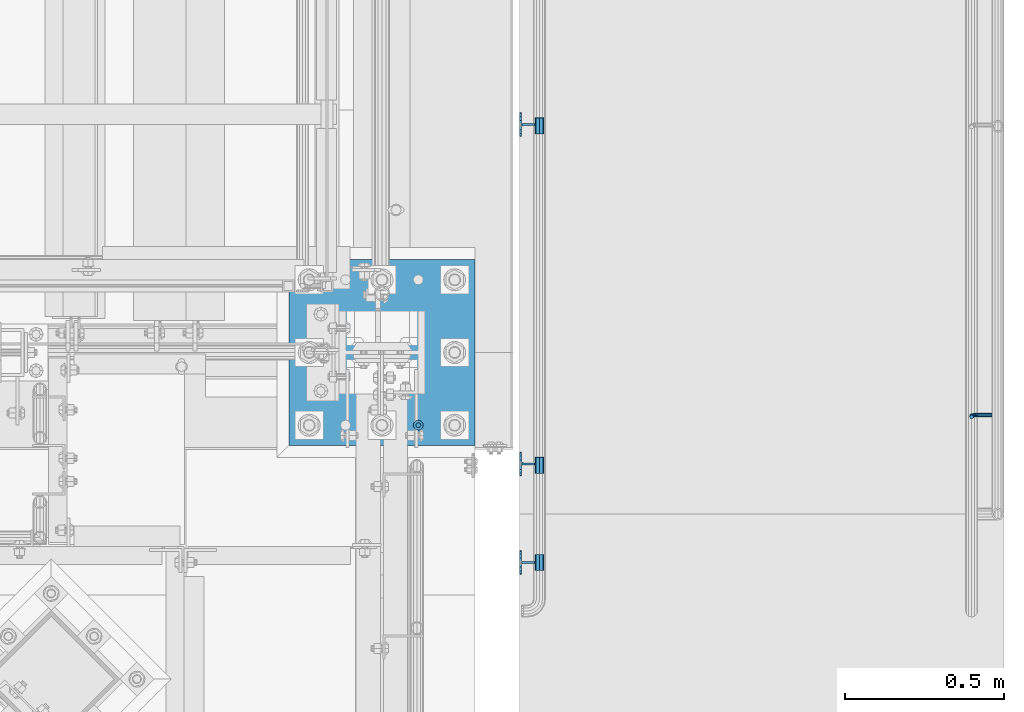
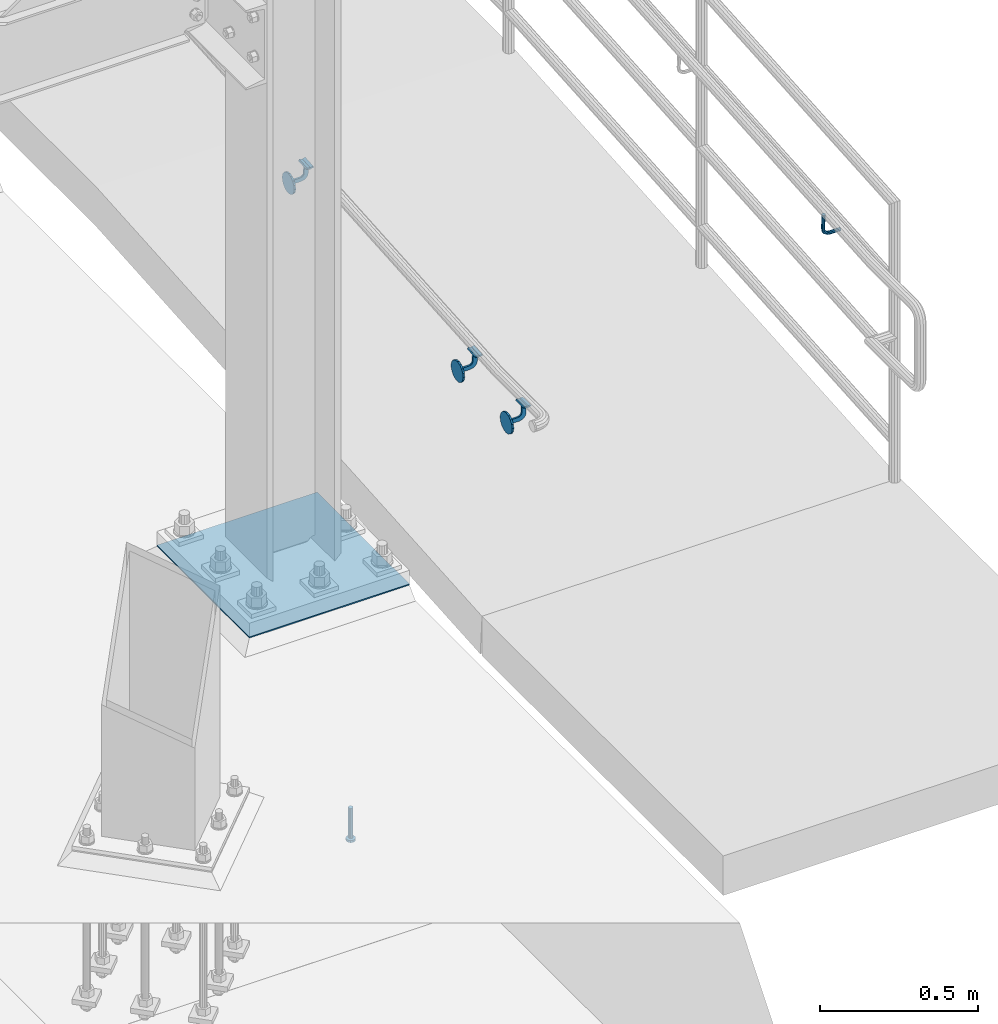
# One storey, part 1216 of 1876: 6 beams, 3 elements without a shape of their own.
"""IFC2X3 building model written with IfcOpenShell, lengths in millimetres."""

from ifc_helpers import new_model, si_unit, frame, origin_with_axes, place, context, subcontext, project, spatial, faceted_brep, material, type_object, element, aggregate, save


model = new_model("IFC2X3")

# Units and contexts
model_context = context("Model", 3, precision=1e-05, world=origin_with_axes())
body_context = subcontext(model_context, "Body", "Model", "MODEL_VIEW")
ifc_project = project(units=[si_unit("LENGTHUNIT", "METRE", prefix="MILLI"), si_unit("AREAUNIT", "SQUARE_METRE"), si_unit("VOLUMEUNIT", "CUBIC_METRE"), si_unit("MASSUNIT", "GRAM", prefix="KILO"), si_unit("TIMEUNIT", "SECOND"), si_unit("PLANEANGLEUNIT", "RADIAN"), si_unit("SOLIDANGLEUNIT", "STERADIAN"), si_unit("THERMODYNAMICTEMPERATUREUNIT", "DEGREE_CELSIUS"), si_unit("LUMINOUSINTENSITYUNIT", "LUMEN")], contexts=[model_context])

# Site, building, storey
site_placement = place(None, origin_with_axes())
site = spatial("IfcSite", under=ifc_project, at=site_placement, CompositionType="ELEMENT")
building_placement = place(site_placement, origin_with_axes())
building = spatial("IfcBuilding", under=site, at=building_placement, Name="Undefined", CompositionType="ELEMENT")
storey_placement = place(building_placement, origin_with_axes())
storey = spatial("IfcBuildingStorey", under=building, at=storey_placement, Name="Undefined", CompositionType="ELEMENT", Elevation=0.0)

# Assembly, beams
assembly_1_placement = place(storey_placement, origin_with_axes())
assembly_1 = element("IfcElementAssembly", 1, at=assembly_1_placement, inside=storey, Name="RAIL", AssemblyPlace="NOTDEFINED", PredefinedType="RIGID_FRAME")
ifc_material_1 = material(Name="STEEL/A36")
beam_type_1 = type_object("IfcBeamType", PredefinedType="NOTDEFINED")
beam_1_placement = place(assembly_1_placement, frame((8058.1501953125, -6395.2584772184, 927.301768827933), z_axis=(0.0, -0.072723596972548, 0.997352133623513), x_axis=(-1.0, 0.0, 0.0)))
beam_1 = element("IfcBeam", 2, at=beam_1_placement, type_object=beam_type_1, material=ifc_material_1, Name="BRACKET", context=body_context, shape_type="Brep", body=[
    faceted_brep([(-46.0130014419665, 25.3999999999842, 59.8739999999966), (-46.0130014419665, -25.4000000000169, 59.8739999999993), (-43.0820493651399, -25.4000000000142, 54.2408818649569), (-43.0820493651399, 25.399999999986, 54.2408818649542), (-57.1500015258825, 25.399999999986, 50.8000000228835), (-71.2179536866233, 25.399999999986, 54.2408818649558), (-68.2870016097968, 25.3999999999833, 59.8739999999977), (-57.1500015258825, 25.3999999999851, 57.1500000228839), (-57.1500015258825, -25.400000000016, 57.1500000228866), (-68.2870016097968, -25.4000000000169, 59.8740000000005), (-71.2179536866233, -25.4000000000142, 54.2408818649587), (-57.1500015258825, -25.4000000000133, 50.8000000228863), (0.0, -35.1998101886738, -14.5802387731073), (0.0, -26.940768363198, -26.9407683632053), (6.34999999999945, -26.940768363198, -26.9407683632053), (6.34999999999945, -35.1998101886738, -14.5802387731073), (0.0, -14.5802387730992, -35.1998101886782), (6.34999999999945, -14.5802387730992, -35.1998101886782), (0.0, 0.0, -38.0999984741338), (6.34999999999945, 1.18234311230481e-11, -38.099999999999), (0.0, 14.580238773121, -35.1998101886797), (6.34999999999945, 14.580238773121, -35.1998101886797), (0.0, 26.9407683632162, -26.940768363208), (6.34999999999945, 26.9407683632162, -26.940768363208), (0.0, 35.1998101886848, -14.5802387731114), (6.34999999999945, 35.1998101886848, -14.5802387731114), (0.0, 38.0999984741211, 0.0), (6.34999999999945, 38.1000000000013, -1.81898940354586e-12), (0.0, 35.1998101886766, 14.5802387731078), (6.34999999999945, 35.1998101886766, 14.5802387731078), (0.0, 26.9407683632007, 26.9407683632055), (6.34999999999945, 26.9407683632007, 26.9407683632055), (0.0, 14.5802387731019, 35.1998101886786), (6.34999999999945, 14.5802387731019, 35.1998101886786), (0.0, 0.0, 38.0999984741338), (6.34999999999945, -1.00044417195022e-11, 38.0999999999992), (0.0, -14.5802387731192, 35.19981018868), (6.34999999999945, -14.5802387731192, 35.19981018868), (0.0, -26.9407683632135, 26.9407683632085), (6.34999999999945, -26.9407683632135, 26.9407683632085), (0.0, -35.199810188682, 14.5802387731117), (6.34999999999945, -35.199810188682, 14.5802387731117), (0.0, -38.0999984741211, 0.0), (6.34999999999945, -38.0999999999985, 2.27373675443232e-12), (-2.81979282590328e-06, 3.17499999999654, 14.2874995937464), (-2.81979282590328e-06, -3.17500000000291, 14.2874995937466), (-5.27939846506342e-07, -3.17499999999472, -14.2874988034032), (-5.27939846506342e-07, 3.17500000000564, -14.2874988034037), (-2.63025660852054, -3.17499999999563, -11.6572431908749), (-4.55477065805098, -3.17499999999563, -10.0778355802022), (-4.55477065805098, 3.17500000000382, -10.0778355802026), (-2.63025660852054, 3.17500000000473, -11.6572431908751), (-6.75043282424667, -3.17499999999563, -8.90422986300769), (-6.75043282424667, 3.17500000000382, -8.90422986300791), (-9.13286505955875, -3.17499999999654, -8.18152703913142), (-9.13286505955875, 3.17500000000382, -8.18152703913188), (-11.6105118489704, -3.17499999999654, -7.93750016682225), (-11.6105118489704, 3.17500000000291, -7.9375001668227), (-39.6875019927193, -3.17499999999654, -7.93750028456952), (-39.6875019927193, 3.17500000000291, -7.93750028456975), (-49.4076610515085, -3.17499999999745, -6.00404047411575), (-49.4076610515085, 3.17500000000291, -6.00404047411621), (-57.6480140186513, -3.17499999999836, -0.498012691431313), (-57.6480140186513, 3.17500000000109, -0.498012691431768), (-63.1540418499671, -3.17500000000109, 7.7423402432164), (-63.1540418499671, 3.17499999999927, 7.74234024321595), (-65.0875017177841, -3.17500000000382, 17.4624992905929), (-65.0875017177841, 3.17499999999563, 17.4624992905926), (-65.087501776512, -3.17500000001382, 51.8520000197409), (-65.087501776512, 3.17499999998563, 51.8520000197404), (-61.1534567902418, -3.17500000001382, 51.0641449225943), (-61.1534567902418, 3.17499999998654, 51.0641449225939), (-57.1500016489963, -3.17500000001382, 50.7999999999995), (-57.1500016489963, 3.17499999998563, 50.799999999999), (-53.1465465050042, -3.17500000001382, 51.0641448809627), (-53.1465465050042, 3.17499999998654, 51.0641448809622), (-49.2125015105412, -3.17500000001382, 51.8519999371995), (-49.2125015105412, 3.17499999998654, 51.8519999371993), (-49.2125019323712, -3.17500000000564, 20.6375022715106), (-49.2125019323712, 3.17499999999472, 20.6375022715101), (-48.2457720829962, -3.17500000000382, 15.7774227585905), (-48.2457720829962, 3.17499999999654, 15.7774227585903), (-45.4927582585078, -3.175000000002, 11.6572462628865), (-45.4927582585078, 3.17499999999745, 11.657246262886), (-41.3725818542835, -3.175000000002, 8.9042323014869), (-41.3725818542835, 3.17499999999927, 8.90423230148645), (-36.5125023734863, -3.17500000000109, 7.93750229061425), (-36.5125023734863, 3.17499999999836, 7.93750229061402), (-11.6105132387529, -3.17500000000109, 7.93750179965673), (-11.6105132387529, 3.17499999999836, 7.9375017996565), (-9.13286624526063, -3.175000000002, 8.18152867334902), (-9.13286624526063, 3.17499999999836, 8.18152867334879), (-6.75043382168133, -3.17500000000109, 8.90423157670512), (-6.75043382168133, 3.17499999999836, 8.90423157670489), (-4.55477150521438, -3.175000000002, 10.077837443888), (-4.55477150521438, 3.17499999999745, 10.0778374438878), (-2.63025736295731, -3.175000000002, 11.6572452619298), (-2.63025736295731, 3.17499999999745, 11.6572452619296)], [[[0, 1, 2, 3]], [[0, 3, 4, 5, 6, 7]], [[8, 1, 0, 7]], [[6, 9, 8, 7]], [[2, 1, 8, 9, 10, 11]], [[4, 3, 2, 11]], [[10, 5, 4, 11]], [[9, 6, 5, 10]], [[12, 13, 14, 15]], [[13, 16, 17, 14]], [[16, 18, 19, 17]], [[18, 20, 21, 19]], [[20, 22, 23, 21]], [[22, 24, 25, 23]], [[24, 26, 27, 25]], [[26, 28, 29, 27]], [[28, 30, 31, 29]], [[30, 32, 33, 31]], [[32, 34, 35, 33]], [[34, 36, 37, 35]], [[36, 38, 39, 37]], [[38, 40, 41, 39]], [[40, 42, 43, 41]], [[14, 17, 19, 21, 23, 25, 27, 29, 31, 33, 35, 37, 39, 41, 43, 15]], [[42, 12, 15, 43]], [[40, 38, 36, 34, 32, 30, 28, 26, 24, 22, 20, 18, 16, 13, 12, 42], [44, 45, 46, 47]], [[48, 49, 50, 51]], [[49, 52, 53, 50]], [[52, 54, 55, 53]], [[54, 56, 57, 55]], [[56, 58, 59, 57]], [[58, 60, 61, 59]], [[60, 62, 63, 61]], [[62, 64, 65, 63]], [[64, 66, 67, 65]], [[66, 68, 69, 67]], [[68, 70, 71, 69]], [[70, 72, 73, 71]], [[72, 74, 75, 73]], [[74, 76, 77, 75]], [[76, 78, 79, 77]], [[78, 80, 81, 79]], [[80, 82, 83, 81]], [[82, 84, 85, 83]], [[84, 86, 87, 85]], [[86, 88, 89, 87]], [[88, 90, 91, 89]], [[90, 92, 93, 91]], [[92, 94, 95, 93]], [[94, 96, 97, 95]], [[97, 96, 45, 44]], [[51, 50, 53, 55, 57, 59, 61, 63, 65, 67, 69, 71, 73, 75, 77, 79, 81, 83, 85, 87, 89, 91, 93, 95, 97, 44, 47]], [[48, 51, 47, 46]], [[96, 94, 92, 90, 88, 86, 84, 82, 80, 78, 76, 74, 72, 70, 68, 66, 64, 62, 60, 58, 56, 54, 52, 49, 48, 46, 45]]]),
])
beam_2_placement = place(assembly_1_placement, frame((8058.1501953125, -7462.46197847771, 849.484843382856), z_axis=(0.0, -0.072723596972548, 0.997352133623513), x_axis=(-1.0, 0.0, 0.0)))
beam_2 = element("IfcBeam", 3, at=beam_2_placement, type_object=beam_type_1, material=ifc_material_1, Name="BRACKET", context=body_context, shape_type="Brep", body=[
    faceted_brep([(-46.0130014419665, 25.3999999999842, 59.8739999999966), (-46.0130014419665, -25.4000000000169, 59.8739999999993), (-43.0820493651399, -25.4000000000142, 54.2408818649569), (-43.0820493651399, 25.399999999986, 54.2408818649542), (-57.1500015258825, 25.399999999986, 50.8000000228835), (-71.2179536866233, 25.399999999986, 54.2408818649558), (-68.2870016097968, 25.3999999999833, 59.8739999999977), (-57.1500015258825, 25.3999999999851, 57.1500000228839), (-57.1500015258825, -25.400000000016, 57.1500000228866), (-68.2870016097968, -25.4000000000169, 59.8740000000005), (-71.2179536866233, -25.4000000000142, 54.2408818649587), (-57.1500015258825, -25.4000000000133, 50.8000000228863), (0.0, -35.1998101886738, -14.5802387731073), (0.0, -26.940768363198, -26.9407683632053), (6.34999999999945, -26.940768363198, -26.9407683632053), (6.34999999999945, -35.1998101886738, -14.5802387731073), (0.0, -14.5802387730992, -35.1998101886782), (6.34999999999945, -14.5802387730992, -35.1998101886782), (0.0, 0.0, -38.0999984741338), (6.34999999999945, 1.18234311230481e-11, -38.099999999999), (0.0, 14.580238773121, -35.1998101886797), (6.34999999999945, 14.580238773121, -35.1998101886797), (0.0, 26.9407683632162, -26.940768363208), (6.34999999999945, 26.9407683632162, -26.940768363208), (0.0, 35.1998101886848, -14.5802387731114), (6.34999999999945, 35.1998101886848, -14.5802387731114), (0.0, 38.0999984741211, 0.0), (6.34999999999945, 38.1000000000013, -1.81898940354586e-12), (0.0, 35.1998101886766, 14.5802387731078), (6.34999999999945, 35.1998101886766, 14.5802387731078), (0.0, 26.9407683632007, 26.9407683632055), (6.34999999999945, 26.9407683632007, 26.9407683632055), (0.0, 14.5802387731019, 35.1998101886786), (6.34999999999945, 14.5802387731019, 35.1998101886786), (0.0, 0.0, 38.0999984741338), (6.34999999999945, -1.00044417195022e-11, 38.0999999999992), (0.0, -14.5802387731192, 35.19981018868), (6.34999999999945, -14.5802387731192, 35.19981018868), (0.0, -26.9407683632135, 26.9407683632085), (6.34999999999945, -26.9407683632135, 26.9407683632085), (0.0, -35.199810188682, 14.5802387731117), (6.34999999999945, -35.199810188682, 14.5802387731117), (0.0, -38.0999984741211, 0.0), (6.34999999999945, -38.0999999999985, 2.27373675443232e-12), (-2.81979282590328e-06, 3.17499999999654, 14.2874995937464), (-2.81979282590328e-06, -3.17500000000291, 14.2874995937466), (-5.27939846506342e-07, -3.17499999999472, -14.2874988034032), (-5.27939846506342e-07, 3.17500000000564, -14.2874988034037), (-2.63025660852054, -3.17499999999563, -11.6572431908749), (-4.55477065805098, -3.17499999999563, -10.0778355802022), (-4.55477065805098, 3.17500000000382, -10.0778355802026), (-2.63025660852054, 3.17500000000473, -11.6572431908751), (-6.75043282424667, -3.17499999999563, -8.90422986300769), (-6.75043282424667, 3.17500000000382, -8.90422986300791), (-9.13286505955875, -3.17499999999654, -8.18152703913142), (-9.13286505955875, 3.17500000000382, -8.18152703913188), (-11.6105118489704, -3.17499999999654, -7.93750016682225), (-11.6105118489704, 3.17500000000291, -7.9375001668227), (-39.6875019927193, -3.17499999999654, -7.93750028456952), (-39.6875019927193, 3.17500000000291, -7.93750028456975), (-49.4076610515085, -3.17499999999745, -6.00404047411575), (-49.4076610515085, 3.17500000000291, -6.00404047411621), (-57.6480140186513, -3.17499999999836, -0.498012691431313), (-57.6480140186513, 3.17500000000109, -0.498012691431768), (-63.1540418499671, -3.17500000000109, 7.7423402432164), (-63.1540418499671, 3.17499999999927, 7.74234024321595), (-65.0875017177841, -3.17500000000382, 17.4624992905929), (-65.0875017177841, 3.17499999999563, 17.4624992905926), (-65.087501776512, -3.17500000001382, 51.8520000197409), (-65.087501776512, 3.17499999998563, 51.8520000197404), (-61.1534567902418, -3.17500000001382, 51.0641449225943), (-61.1534567902418, 3.17499999998654, 51.0641449225939), (-57.1500016489963, -3.17500000001382, 50.7999999999995), (-57.1500016489963, 3.17499999998563, 50.799999999999), (-53.1465465050042, -3.17500000001382, 51.0641448809627), (-53.1465465050042, 3.17499999998654, 51.0641448809622), (-49.2125015105412, -3.17500000001382, 51.8519999371995), (-49.2125015105412, 3.17499999998654, 51.8519999371993), (-49.2125019323712, -3.17500000000564, 20.6375022715106), (-49.2125019323712, 3.17499999999472, 20.6375022715101), (-48.2457720829962, -3.17500000000382, 15.7774227585905), (-48.2457720829962, 3.17499999999654, 15.7774227585903), (-45.4927582585078, -3.175000000002, 11.6572462628865), (-45.4927582585078, 3.17499999999745, 11.657246262886), (-41.3725818542835, -3.175000000002, 8.9042323014869), (-41.3725818542835, 3.17499999999927, 8.90423230148645), (-36.5125023734863, -3.17500000000109, 7.93750229061425), (-36.5125023734863, 3.17499999999836, 7.93750229061402), (-11.6105132387529, -3.17500000000109, 7.93750179965673), (-11.6105132387529, 3.17499999999836, 7.9375017996565), (-9.13286624526063, -3.175000000002, 8.18152867334902), (-9.13286624526063, 3.17499999999836, 8.18152867334879), (-6.75043382168133, -3.17500000000109, 8.90423157670512), (-6.75043382168133, 3.17499999999836, 8.90423157670489), (-4.55477150521438, -3.175000000002, 10.077837443888), (-4.55477150521438, 3.17499999999745, 10.0778374438878), (-2.63025736295731, -3.175000000002, 11.6572452619298), (-2.63025736295731, 3.17499999999745, 11.6572452619296)], [[[0, 1, 2, 3]], [[0, 3, 4, 5, 6, 7]], [[8, 1, 0, 7]], [[6, 9, 8, 7]], [[2, 1, 8, 9, 10, 11]], [[4, 3, 2, 11]], [[10, 5, 4, 11]], [[9, 6, 5, 10]], [[12, 13, 14, 15]], [[13, 16, 17, 14]], [[16, 18, 19, 17]], [[18, 20, 21, 19]], [[20, 22, 23, 21]], [[22, 24, 25, 23]], [[24, 26, 27, 25]], [[26, 28, 29, 27]], [[28, 30, 31, 29]], [[30, 32, 33, 31]], [[32, 34, 35, 33]], [[34, 36, 37, 35]], [[36, 38, 39, 37]], [[38, 40, 41, 39]], [[40, 42, 43, 41]], [[14, 17, 19, 21, 23, 25, 27, 29, 31, 33, 35, 37, 39, 41, 43, 15]], [[42, 12, 15, 43]], [[40, 38, 36, 34, 32, 30, 28, 26, 24, 22, 20, 18, 16, 13, 12, 42], [44, 45, 46, 47]], [[48, 49, 50, 51]], [[49, 52, 53, 50]], [[52, 54, 55, 53]], [[54, 56, 57, 55]], [[56, 58, 59, 57]], [[58, 60, 61, 59]], [[60, 62, 63, 61]], [[62, 64, 65, 63]], [[64, 66, 67, 65]], [[66, 68, 69, 67]], [[68, 70, 71, 69]], [[70, 72, 73, 71]], [[72, 74, 75, 73]], [[74, 76, 77, 75]], [[76, 78, 79, 77]], [[78, 80, 81, 79]], [[80, 82, 83, 81]], [[82, 84, 85, 83]], [[84, 86, 87, 85]], [[86, 88, 89, 87]], [[88, 90, 91, 89]], [[90, 92, 93, 91]], [[92, 94, 95, 93]], [[94, 96, 97, 95]], [[97, 96, 45, 44]], [[51, 50, 53, 55, 57, 59, 61, 63, 65, 67, 69, 71, 73, 75, 77, 79, 81, 83, 85, 87, 89, 91, 93, 95, 97, 44, 47]], [[48, 51, 47, 46]], [[96, 94, 92, 90, 88, 86, 84, 82, 80, 78, 76, 74, 72, 70, 68, 66, 64, 62, 60, 58, 56, 54, 52, 49, 48, 46, 45]]]),
])
beam_3_placement = place(assembly_1_placement, frame((8058.1501953125, -7772.39999999987, 838.199999977106), z_axis=(0.0, 0.0, 1.0), x_axis=(-1.0, 0.0, 0.0)))
beam_3 = element("IfcBeam", 4, at=beam_3_placement, type_object=beam_type_1, material=ifc_material_1, Name="BRACKET", context=body_context, shape_type="Brep", body=[
    faceted_brep([(-46.0130014419665, 25.3999999999842, 59.8739999999966), (-46.0130014419665, -25.4000000000169, 59.8739999999993), (-43.0820493651399, -25.4000000000142, 54.2408818649569), (-43.0820493651399, 25.399999999986, 54.2408818649542), (-57.1500015258825, 25.399999999986, 50.8000000228835), (-71.2179536866233, 25.399999999986, 54.2408818649558), (-68.2870016097968, 25.3999999999833, 59.8739999999977), (-57.1500015258825, 25.3999999999851, 57.1500000228839), (-57.1500015258825, -25.400000000016, 57.1500000228866), (-68.2870016097968, -25.4000000000169, 59.8740000000005), (-71.2179536866233, -25.4000000000142, 54.2408818649587), (-57.1500015258825, -25.4000000000133, 50.8000000228863), (0.0, -35.1998101886738, -14.5802387731073), (0.0, -26.940768363198, -26.9407683632053), (6.34999999999945, -26.940768363198, -26.9407683632053), (6.34999999999945, -35.1998101886738, -14.5802387731073), (0.0, -14.5802387730992, -35.1998101886782), (6.34999999999945, -14.5802387730992, -35.1998101886782), (0.0, 0.0, -38.0999984741338), (6.34999999999945, 1.18234311230481e-11, -38.099999999999), (0.0, 14.580238773121, -35.1998101886797), (6.34999999999945, 14.580238773121, -35.1998101886797), (0.0, 26.9407683632162, -26.940768363208), (6.34999999999945, 26.9407683632162, -26.940768363208), (0.0, 35.1998101886848, -14.5802387731114), (6.34999999999945, 35.1998101886848, -14.5802387731114), (0.0, 38.0999984741211, 0.0), (6.34999999999945, 38.1000000000013, -1.81898940354586e-12), (0.0, 35.1998101886766, 14.5802387731078), (6.34999999999945, 35.1998101886766, 14.5802387731078), (0.0, 26.9407683632007, 26.9407683632055), (6.34999999999945, 26.9407683632007, 26.9407683632055), (0.0, 14.5802387731019, 35.1998101886786), (6.34999999999945, 14.5802387731019, 35.1998101886786), (0.0, 0.0, 38.0999984741338), (6.34999999999945, -1.00044417195022e-11, 38.0999999999992), (0.0, -14.5802387731192, 35.19981018868), (6.34999999999945, -14.5802387731192, 35.19981018868), (0.0, -26.9407683632135, 26.9407683632085), (6.34999999999945, -26.9407683632135, 26.9407683632085), (0.0, -35.199810188682, 14.5802387731117), (6.34999999999945, -35.199810188682, 14.5802387731117), (0.0, -38.0999984741211, 0.0), (6.34999999999945, -38.0999999999985, 2.27373675443232e-12), (-2.81979282590328e-06, 3.17499999999654, 14.2874995937464), (-2.81979282590328e-06, -3.17500000000291, 14.2874995937466), (-5.27939846506342e-07, -3.17499999999472, -14.2874988034032), (-5.27939846506342e-07, 3.17500000000564, -14.2874988034037), (-2.63025660852054, -3.17499999999563, -11.6572431908749), (-4.55477065805098, -3.17499999999563, -10.0778355802022), (-4.55477065805098, 3.17500000000382, -10.0778355802026), (-2.63025660852054, 3.17500000000473, -11.6572431908751), (-6.75043282424667, -3.17499999999563, -8.90422986300769), (-6.75043282424667, 3.17500000000382, -8.90422986300791), (-9.13286505955875, -3.17499999999654, -8.18152703913142), (-9.13286505955875, 3.17500000000382, -8.18152703913188), (-11.6105118489704, -3.17499999999654, -7.93750016682225), (-11.6105118489704, 3.17500000000291, -7.9375001668227), (-39.6875019927193, -3.17499999999654, -7.93750028456952), (-39.6875019927193, 3.17500000000291, -7.93750028456975), (-49.4076610515085, -3.17499999999745, -6.00404047411575), (-49.4076610515085, 3.17500000000291, -6.00404047411621), (-57.6480140186513, -3.17499999999836, -0.498012691431313), (-57.6480140186513, 3.17500000000109, -0.498012691431768), (-63.1540418499671, -3.17500000000109, 7.7423402432164), (-63.1540418499671, 3.17499999999927, 7.74234024321595), (-65.0875017177841, -3.17500000000382, 17.4624992905929), (-65.0875017177841, 3.17499999999563, 17.4624992905926), (-65.087501776512, -3.17500000001382, 51.8520000197409), (-65.087501776512, 3.17499999998563, 51.8520000197404), (-61.1534567902418, -3.17500000001382, 51.0641449225943), (-61.1534567902418, 3.17499999998654, 51.0641449225939), (-57.1500016489963, -3.17500000001382, 50.7999999999995), (-57.1500016489963, 3.17499999998563, 50.799999999999), (-53.1465465050042, -3.17500000001382, 51.0641448809627), (-53.1465465050042, 3.17499999998654, 51.0641448809622), (-49.2125015105412, -3.17500000001382, 51.8519999371995), (-49.2125015105412, 3.17499999998654, 51.8519999371993), (-49.2125019323712, -3.17500000000564, 20.6375022715106), (-49.2125019323712, 3.17499999999472, 20.6375022715101), (-48.2457720829962, -3.17500000000382, 15.7774227585905), (-48.2457720829962, 3.17499999999654, 15.7774227585903), (-45.4927582585078, -3.175000000002, 11.6572462628865), (-45.4927582585078, 3.17499999999745, 11.657246262886), (-41.3725818542835, -3.175000000002, 8.9042323014869), (-41.3725818542835, 3.17499999999927, 8.90423230148645), (-36.5125023734863, -3.17500000000109, 7.93750229061425), (-36.5125023734863, 3.17499999999836, 7.93750229061402), (-11.6105132387529, -3.17500000000109, 7.93750179965673), (-11.6105132387529, 3.17499999999836, 7.9375017996565), (-9.13286624526063, -3.175000000002, 8.18152867334902), (-9.13286624526063, 3.17499999999836, 8.18152867334879), (-6.75043382168133, -3.17500000000109, 8.90423157670512), (-6.75043382168133, 3.17499999999836, 8.90423157670489), (-4.55477150521438, -3.175000000002, 10.077837443888), (-4.55477150521438, 3.17499999999745, 10.0778374438878), (-2.63025736295731, -3.175000000002, 11.6572452619298), (-2.63025736295731, 3.17499999999745, 11.6572452619296)], [[[0, 1, 2, 3]], [[0, 3, 4, 5, 6, 7]], [[8, 1, 0, 7]], [[6, 9, 8, 7]], [[2, 1, 8, 9, 10, 11]], [[4, 3, 2, 11]], [[10, 5, 4, 11]], [[9, 6, 5, 10]], [[12, 13, 14, 15]], [[13, 16, 17, 14]], [[16, 18, 19, 17]], [[18, 20, 21, 19]], [[20, 22, 23, 21]], [[22, 24, 25, 23]], [[24, 26, 27, 25]], [[26, 28, 29, 27]], [[28, 30, 31, 29]], [[30, 32, 33, 31]], [[32, 34, 35, 33]], [[34, 36, 37, 35]], [[36, 38, 39, 37]], [[38, 40, 41, 39]], [[40, 42, 43, 41]], [[14, 17, 19, 21, 23, 25, 27, 29, 31, 33, 35, 37, 39, 41, 43, 15]], [[42, 12, 15, 43]], [[40, 38, 36, 34, 32, 30, 28, 26, 24, 22, 20, 18, 16, 13, 12, 42], [44, 45, 46, 47]], [[48, 49, 50, 51]], [[49, 52, 53, 50]], [[52, 54, 55, 53]], [[54, 56, 57, 55]], [[56, 58, 59, 57]], [[58, 60, 61, 59]], [[60, 62, 63, 61]], [[62, 64, 65, 63]], [[64, 66, 67, 65]], [[66, 68, 69, 67]], [[68, 70, 71, 69]], [[70, 72, 73, 71]], [[72, 74, 75, 73]], [[74, 76, 77, 75]], [[76, 78, 79, 77]], [[78, 80, 81, 79]], [[80, 82, 83, 81]], [[82, 84, 85, 83]], [[84, 86, 87, 85]], [[86, 88, 89, 87]], [[88, 90, 91, 89]], [[90, 92, 93, 91]], [[92, 94, 95, 93]], [[94, 96, 97, 95]], [[97, 96, 45, 44]], [[51, 50, 53, 55, 57, 59, 61, 63, 65, 67, 69, 71, 73, 75, 77, 79, 81, 83, 85, 87, 89, 91, 93, 95, 97, 44, 47]], [[48, 51, 47, 46]], [[96, 94, 92, 90, 88, 86, 84, 82, 80, 78, 76, 74, 72, 70, 68, 66, 64, 62, 60, 58, 56, 54, 52, 49, 48, 46, 45]]]),
])
aggregate(assembly_1, [beam_1, beam_2, beam_3])

# Assembly, beam
assembly_2_placement = place(storey_placement, origin_with_axes())
assembly_2 = element("IfcElementAssembly", 5, at=assembly_2_placement, inside=storey, Name="RAIL", AssemblyPlace="NOTDEFINED", PredefinedType="RIGID_FRAME")
beam_type_2 = type_object("IfcBeamType", PredefinedType="NOTDEFINED")
beam_4_placement = place(assembly_2_placement, frame((9537.7001953125, -7308.61834773, 784.435175341177), z_axis=(0.0, 0.997352133623513, 0.0727235969725478), x_axis=(-1.0, 0.0, 0.0)))
beam_4 = element("IfcBeam", 6, at=beam_4_placement, type_object=beam_type_2, material=ifc_material_1, Name="BRACKET", context=body_context, shape_type="Brep", body=[
    faceted_brep([(0.0, -6.35000000000036, 0.0), (0.0, -4.49012806053463, -4.49012806053452), (38.1000003814697, -4.49012806053463, -4.49012806053452), (38.1000003814697, -6.35000000000002, 0.0), (0.0, 0.0, -6.34999999999991), (38.1000003814697, 0.0, -6.34999999999991), (0.0, 4.49012806053463, -4.49012806053452), (38.1000003814697, 4.49012806053463, -4.49012806053452), (0.0, 6.35000000000036, 0.0), (38.1000003814697, 6.35000000000002, 0.0), (0.0, 4.49012806053463, 4.49012806053452), (38.1000003814697, 4.49012806053463, 4.49012806053452), (0.0, 0.0, 6.34999999999991), (38.1000003814697, 0.0, 6.34999999999991), (0.0, -4.49012806053463, 4.49012806053452), (38.1000003814697, -4.49012806053463, 4.49012806053452), (50.2501992130801, -3.93317518627066, 0.0), (49.5384570355254, -2.21487756830652, 4.49012806053452), (47.8201594175607, 1.93345984517589, 6.34999999999991), (46.1018617995978, 6.08179725865841, 4.49012806053452), (45.3901196220431, 7.80009487662255, 0.0), (46.1018617995978, 6.08179725865841, -4.49012806053452), (47.8201594175607, 1.93345984517589, -6.34999999999991), (49.5384570355254, -2.21487756830652, -4.49012806053452), (59.2355123538691, 4.26448764613235, -4.49012806053452), (60.5506404144035, 2.9493595855979, 0.0), (56.060512353868, 7.43948764613231, -6.34999999999991), (52.8855123538688, 10.6144876461323, -4.49012806053452), (51.5703842933344, 11.9296157066667, 0.0), (52.8855123538688, 10.6144876461323, 4.49012806053452), (56.060512353868, 7.43948764613231, 6.34999999999991), (59.2355123538691, 4.26448764613235, 4.49012806053452), (65.7148775683072, 13.9615429644757, -4.49012806053452), (67.4331751862719, 13.2498007869216, 0.0), (61.5665401548249, 15.6798405824397, -6.34999999999991), (57.4182027413426, 17.3981382004039, -4.49012806053452), (55.6999051233779, 18.1098803779579, 0.0), (57.4182027413426, 17.3981382004039, 4.49012806053452), (61.5665401548249, 15.6798405824397, 6.34999999999991), (65.7148775683072, 13.9615429644757, 4.49012806053452), (67.9901280605336, 25.3999996185304, -4.49012806053452), (69.8500000000004, 25.3999996185303, 0.0), (63.5, 25.3999996185303, -6.34999999999991), (59.0098719394646, 25.3999996185303, -4.49012806053452), (57.1499999999996, 25.3999996185303, 0.0), (59.0098719394646, 25.3999996185303, 4.49012806053452), (63.5, 25.3999996185303, 6.34999999999991), (67.9901280605336, 25.3999996185304, 4.49012806053452), (67.9901280605354, 82.5500030517578, -4.49012806053452), (69.8500000000004, 82.5500030517578, 0.0), (63.5, 82.5500030517578, -6.34999999999991), (59.0098719394646, 82.5500030517578, -4.49012806053452), (57.1499999999996, 82.5500030517578, 0.0), (59.0098719394646, 82.5500030517578, 4.49012806053452), (63.5, 82.5500030517578, 6.34999999999991), (67.9901280605354, 82.5500030517578, 4.49012806053452)], [[[0, 1, 2, 3]], [[1, 4, 5, 2]], [[4, 6, 7, 5]], [[6, 8, 9, 7]], [[8, 10, 11, 9]], [[10, 12, 13, 11]], [[12, 14, 15, 13]], [[14, 0, 3, 15]], [[14, 12, 10, 8, 6, 4, 1, 0]], [[15, 3, 16, 17]], [[13, 15, 17, 18]], [[11, 13, 18, 19]], [[9, 11, 19, 20]], [[7, 9, 20, 21]], [[5, 7, 21, 22]], [[2, 5, 22, 23]], [[3, 2, 23, 16]], [[23, 24, 25, 16]], [[22, 26, 24, 23]], [[21, 27, 26, 22]], [[20, 28, 27, 21]], [[19, 29, 28, 20]], [[18, 30, 29, 19]], [[17, 31, 30, 18]], [[16, 25, 31, 17]], [[24, 32, 33, 25]], [[26, 34, 32, 24]], [[27, 35, 34, 26]], [[28, 36, 35, 27]], [[29, 37, 36, 28]], [[30, 38, 37, 29]], [[31, 39, 38, 30]], [[25, 33, 39, 31]], [[32, 40, 41, 33]], [[34, 42, 40, 32]], [[35, 43, 42, 34]], [[36, 44, 43, 35]], [[37, 45, 44, 36]], [[38, 46, 45, 37]], [[39, 47, 46, 38]], [[33, 41, 47, 39]], [[41, 40, 48, 49]], [[40, 42, 50, 48]], [[42, 43, 51, 50]], [[43, 44, 52, 51]], [[44, 45, 53, 52]], [[45, 46, 54, 53]], [[46, 47, 55, 54]], [[47, 41, 49, 55]], [[50, 51, 52, 53, 54, 55, 49, 48]]]),
])
aggregate(assembly_2, [beam_4])

# Assembly, beams
assembly_3_placement = place(storey_placement, origin_with_axes())
assembly_3 = element("IfcElementAssembly", 7, at=assembly_3_placement, inside=storey, Name="TEMPLATE", AssemblyPlace="NOTDEFINED", PredefinedType="RIGID_FRAME")
ifc_material_2 = material(Name="STEEL/A108")
beam_type_3 = type_object("IfcBeamType", Name="5/8-DIA_HEADED ANCHOR STUD", PredefinedType="NOTDEFINED")
beam_5_placement = place(assembly_3_placement, frame((7734.3, -7340.6, -793.75), z_axis=(1.0, 0.0, 0.0), x_axis=(0.0, 0.0, -1.0)))
beam_5 = element("IfcBeam", 8, at=beam_5_placement, type_object=beam_type_3, material=ifc_material_2, Name="HEADED ANCHOR STUD", ObjectType="5/8-DIA_HEADED ANCHOR STUD", context=body_context, shape_type="Brep", body=[
    faceted_brep([(0.0, -7.94000005722046, 0.0), (0.0, -6.86999988555908, -3.97000002861023), (116.84, -6.86999988555908, -3.97000002861023), (116.84, -7.94000005722046, 0.0), (0.0, -3.97000002861023, -6.86999988555908), (116.84, -3.97000002861023, -6.86999988555908), (0.0, 0.0, -7.94000005722046), (116.84, 0.0, -7.94000005722046), (0.0, 3.97000002861023, -6.86999988555908), (116.84, 3.97000002861023, -6.86999988555908), (0.0, 6.86999988555908, -3.97000002861023), (116.84, 6.86999988555908, -3.97000002861023), (0.0, 7.94000005722046, 0.0), (116.84, 7.94000005722046, 0.0), (0.0, 6.86999988555908, 3.97000002861023), (116.84, 6.86999988555908, 3.97000002861023), (0.0, 3.97000002861023, 6.86999988555908), (116.84, 3.97000002861023, 6.86999988555908), (0.0, 0.0, 7.94000005722046), (116.84, 0.0, 7.94000005722046), (0.0, -3.97000002861023, 6.86999988555908), (116.84, -3.97000002861023, 6.86999988555908), (0.0, -6.86999988555908, 3.97000002861023), (116.84, -6.86999988555908, 3.97000002861023), (118.11, -13.75, -7.94000005722046), (118.11, -15.8800001144409, 0.0), (118.11, -7.94000005722046, -13.75), (118.11, 0.0, -15.8800001144409), (118.11, 7.94000005722046, -13.75), (118.11, 13.75, -7.94000005722046), (118.11, 15.8800001144409, 0.0), (118.11, 13.75, 7.94000005722046), (118.11, 7.94000005722046, 13.75), (118.11, 0.0, 15.8800001144409), (118.11, -7.94000005722046, 13.75), (118.11, -13.75, 7.94000005722046), (127.0, -13.75, -7.94000005722046), (127.0, -15.8800001144409, 0.0), (127.0, -7.94000005722046, -13.75), (127.0, 0.0, -15.8800001144409), (127.0, 7.94000005722046, -13.75), (127.0, 13.75, -7.94000005722046), (127.0, 15.8800001144409, 0.0), (127.0, 13.75, 7.94000005722046), (127.0, 7.94000005722046, 13.75), (127.0, 0.0, 15.8800001144409), (127.0, -7.94000005722046, 13.75), (127.0, -13.75, 7.94000005722046)], [[[0, 1, 2, 3]], [[1, 4, 5, 2]], [[4, 6, 7, 5]], [[6, 8, 9, 7]], [[8, 10, 11, 9]], [[10, 12, 13, 11]], [[12, 14, 15, 13]], [[14, 16, 17, 15]], [[16, 18, 19, 17]], [[18, 20, 21, 19]], [[20, 22, 23, 21]], [[22, 0, 3, 23]], [[22, 20, 18, 16, 14, 12, 10, 8, 6, 4, 1, 0]], [[3, 2, 24, 25]], [[2, 5, 26, 24]], [[5, 7, 27, 26]], [[7, 9, 28, 27]], [[9, 11, 29, 28]], [[11, 13, 30, 29]], [[13, 15, 31, 30]], [[15, 17, 32, 31]], [[17, 19, 33, 32]], [[19, 21, 34, 33]], [[21, 23, 35, 34]], [[23, 3, 25, 35]], [[25, 24, 36, 37]], [[24, 26, 38, 36]], [[26, 27, 39, 38]], [[27, 28, 40, 39]], [[28, 29, 41, 40]], [[29, 30, 42, 41]], [[30, 31, 43, 42]], [[31, 32, 44, 43]], [[32, 33, 45, 44]], [[33, 34, 46, 45]], [[34, 35, 47, 46]], [[35, 25, 37, 47]], [[38, 39, 40, 41, 42, 43, 44, 45, 46, 47, 37, 36]]]),
])
beam_type_4 = type_object("IfcBeamType", PredefinedType="NOTDEFINED")
beam_6_placement = place(assembly_3_placement, frame((7912.1, -7112.0, 40.4815), z_axis=(0.0, -1.0, 0.0), x_axis=(-1.0, 0.0, 0.0)))
beam_6 = element("IfcBeam", 9, at=beam_6_placement, type_object=beam_type_4, material=ifc_material_1, Name="TEMPLATE", context=body_context, shape_type="Brep", body=[
    faceted_brep([(0.0, 2.3815, -292.1), (0.0, 2.3815, 292.1), (584.200000000001, 2.3815, 292.1), (584.200000000001, 2.3815, -292.1), (0.0, -2.3815, 292.1), (584.200000000001, -2.3815, 292.1), (0.0, -2.3815, -292.1), (584.200000000001, -2.3815, -292.1)], [[[0, 1, 2, 3]], [[1, 4, 5, 2]], [[4, 6, 7, 5]], [[6, 0, 3, 7]], [[5, 7, 3, 2]], [[6, 4, 1, 0]]]),
])
aggregate(assembly_3, [beam_5, beam_6])

save(model, "model.ifc")
